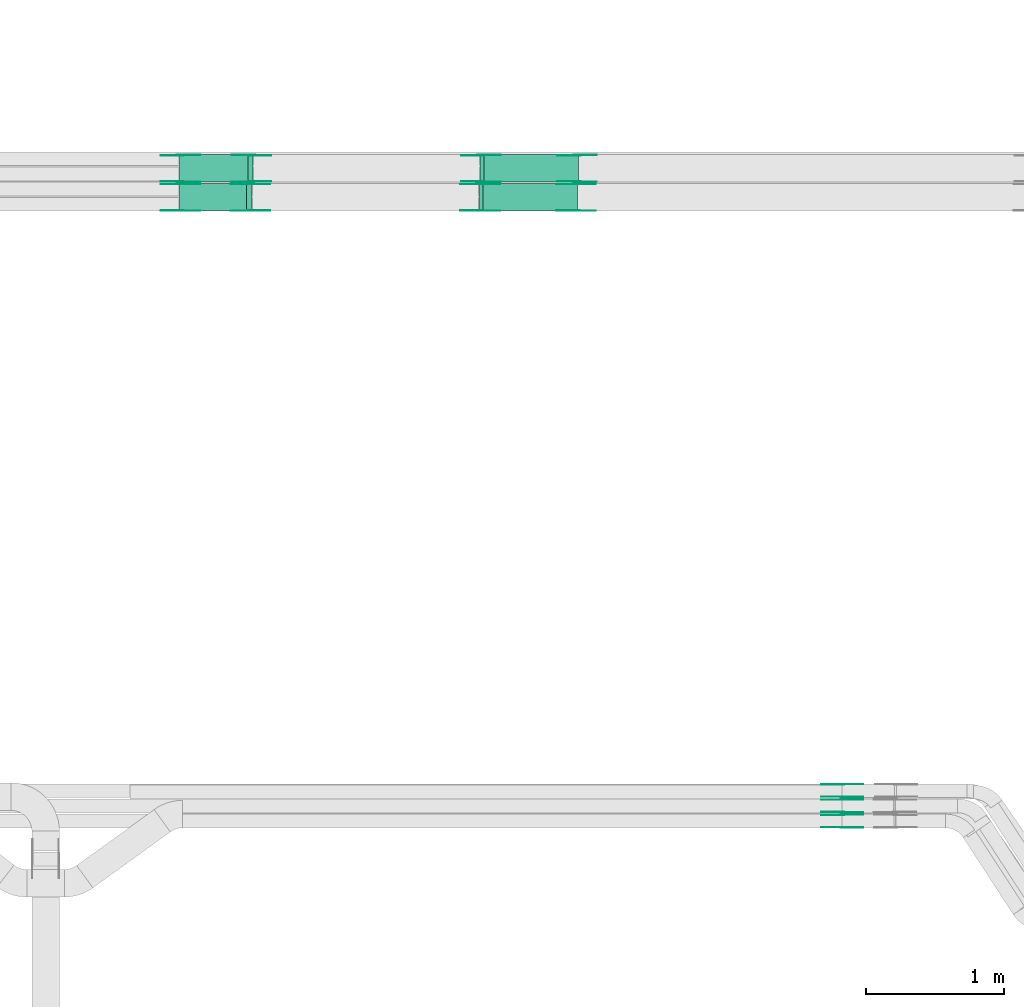
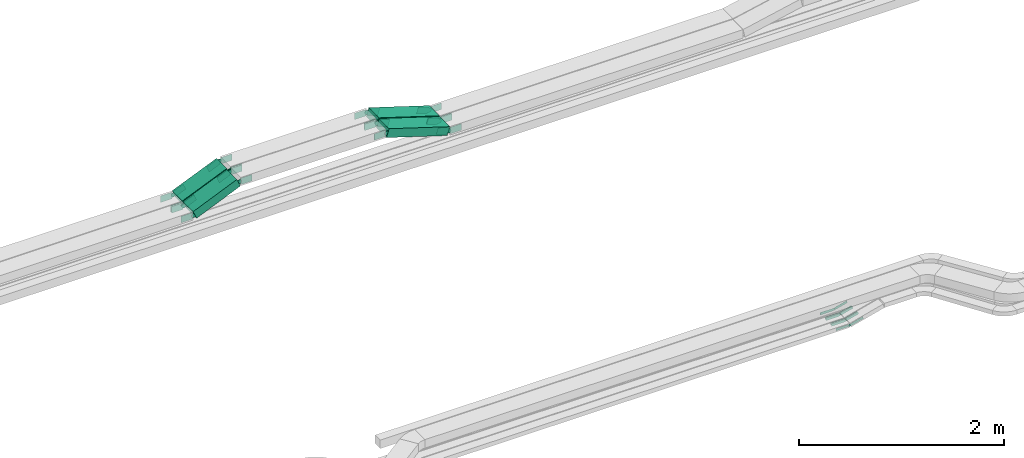
# One storey, part 6 of 23: 44 flow fittings, 4 flow segments.
"""IFC2X3 building model written with IfcOpenShell, lengths in millimetres."""

from ifc_helpers import new_model, entity, si_unit, converted_unit, derived_unit, direction, frame, frame_2d, origin, origin_2d_with_axis, place, context, subcontext, project, spatial, polyline, circle_curve, parameter, trimmed, segment, composite_curve, rectangle, outline, extrude, source, transform, mapped, material, type_object, type_shapes, element, save


model = new_model("IFC2X3")

# Units and contexts
model_context = context("Model", 3, precision=0.01, world=origin(), true_north=direction((6.12303176911189e-17, 1.0)))
body_context = subcontext(model_context, "Body", "Model", "MODEL_VIEW")
ifc_project = project(units=[si_unit("LENGTHUNIT", "METRE", prefix="MILLI"), si_unit("AREAUNIT", "SQUARE_METRE"), si_unit("VOLUMEUNIT", "CUBIC_METRE"), converted_unit("PLANEANGLEUNIT", "DEGREE", entity("IfcRatioMeasure", 0.0174532925199433), si_unit("PLANEANGLEUNIT", "RADIAN"), dimensions=[0, 0, 0, 0, 0, 0, 0]), si_unit("MASSUNIT", "GRAM", prefix="KILO"), derived_unit("MASSDENSITYUNIT", [(si_unit("MASSUNIT", "GRAM", prefix="KILO"), 1), (si_unit("LENGTHUNIT", "METRE"), -3)]), derived_unit("MOMENTOFINERTIAUNIT", [(si_unit("LENGTHUNIT", "METRE"), 4)]), si_unit("TIMEUNIT", "SECOND"), si_unit("FREQUENCYUNIT", "HERTZ"), si_unit("THERMODYNAMICTEMPERATUREUNIT", "DEGREE_CELSIUS"), derived_unit("THERMALTRANSMITTANCEUNIT", [(si_unit("MASSUNIT", "GRAM", prefix="KILO"), 1), (si_unit("THERMODYNAMICTEMPERATUREUNIT", "KELVIN"), -1), (si_unit("TIMEUNIT", "SECOND"), -3)]), derived_unit("VOLUMETRICFLOWRATEUNIT", [(si_unit("LENGTHUNIT", "METRE"), 3), (si_unit("TIMEUNIT", "SECOND"), -1)]), derived_unit("MASSFLOWRATEUNIT", [(si_unit("MASSUNIT", "GRAM", prefix="KILO"), 1), (si_unit("TIMEUNIT", "SECOND"), -1)]), derived_unit("ROTATIONALFREQUENCYUNIT", [(si_unit("TIMEUNIT", "SECOND"), -1)]), si_unit("ELECTRICCURRENTUNIT", "AMPERE"), si_unit("ELECTRICVOLTAGEUNIT", "VOLT"), si_unit("POWERUNIT", "WATT"), si_unit("FORCEUNIT", "NEWTON", prefix="KILO"), si_unit("ILLUMINANCEUNIT", "LUX"), si_unit("LUMINOUSFLUXUNIT", "LUMEN"), si_unit("LUMINOUSINTENSITYUNIT", "CANDELA"), derived_unit("USERDEFINED", [(si_unit("MASSUNIT", "GRAM", prefix="KILO"), -1), (si_unit("LENGTHUNIT", "METRE"), -2), (si_unit("TIMEUNIT", "SECOND"), 3), (si_unit("LUMINOUSFLUXUNIT", "LUMEN"), 1)]), derived_unit("LINEARVELOCITYUNIT", [(si_unit("LENGTHUNIT", "METRE"), 1), (si_unit("TIMEUNIT", "SECOND"), -1)]), si_unit("PRESSUREUNIT", "PASCAL"), derived_unit("USERDEFINED", [(si_unit("LENGTHUNIT", "METRE"), -2), (si_unit("MASSUNIT", "GRAM", prefix="KILO"), 1), (si_unit("TIMEUNIT", "SECOND"), -2)]), derived_unit("LINEARFORCEUNIT", [(si_unit("MASSUNIT", "GRAM", prefix="KILO"), 1), (si_unit("LENGTHUNIT", "METRE"), 1), (si_unit("TIMEUNIT", "SECOND"), -2), (si_unit("LENGTHUNIT", "METRE"), -1)]), derived_unit("PLANARFORCEUNIT", [(si_unit("MASSUNIT", "GRAM", prefix="KILO"), 1), (si_unit("LENGTHUNIT", "METRE"), 1), (si_unit("TIMEUNIT", "SECOND"), -2), (si_unit("LENGTHUNIT", "METRE"), -2)])], contexts=[model_context])

# Site, building, storey
site_placement = place(None, origin())
site = spatial("IfcSite", under=ifc_project, at=site_placement, CompositionType="ELEMENT")
building_placement = place(site_placement, origin())
building = spatial("IfcBuilding", under=site, at=building_placement, CompositionType="ELEMENT")
storey_placement = place(building_placement, frame((0.0, 0.0, 24000.0)))
storey = spatial("IfcBuildingStorey", under=building, at=storey_placement, CompositionType="ELEMENT", Elevation=24000.0)

# Flow segments
cable_carrier_segment_type = type_object("IfcCableCarrierSegmentType", PredefinedType="CABLETRAYSEGMENT")
flow_segment_1_placement = place(storey_placement, frame((23750.35, 14577.82, 2908.57)))
element("IfcFlowSegment", 1, at=flow_segment_1_placement, inside=storey, type_object=cable_carrier_segment_type, context=body_context, shape_type="SweptSolid", body=[
    extrude(rectangle(XDim=99.9999999999979, YDim=200.000000000002, at=origin_2d_with_axis()), frame((19.44, 100.0, 46.07), z_axis=(0.921307677757376, 0.0, 0.388834364357512), x_axis=(-0.388834364357512, 0.0, 0.921307677757376)), (0.0, 0.0, 1.0), 541.93656678797),
])
flow_segment_2_placement = place(storey_placement, frame((25932.66, 14577.82, 2905.08)))
element("IfcFlowSegment", 2, at=flow_segment_2_placement, inside=storey, type_object=cable_carrier_segment_type, context=body_context, shape_type="SweptSolid", body=[
    extrude(rectangle(XDim=99.9999999999984, YDim=200.000000000002, at=origin_2d_with_axis()), frame((14.99, 100.0, 262.13), z_axis=(0.953993716901251, 0.0, -0.299826596740408), x_axis=(0.299826596740408, 0.0, 0.953993716901251)), (0.0, 0.0, 1.0), 715.185612494235),
])
flow_segment_3_placement = place(storey_placement, frame((23750.22, 14367.82, 2908.78)))
element("IfcFlowSegment", 3, at=flow_segment_3_placement, inside=storey, type_object=cable_carrier_segment_type, context=body_context, shape_type="SweptSolid", body=[
    extrude(rectangle(XDim=99.9999999999976, YDim=200.000000000002, at=origin_2d_with_axis()), frame((19.67, 100.0, 45.97), z_axis=(0.919387135984397, 0.0, 0.393353904501287), x_axis=(-0.393353904501287, 0.0, 0.919387135984397)), (0.0, 0.0, 1.0), 535.159561068118),
])
flow_segment_4_placement = place(storey_placement, frame((25925.6, 14367.82, 2905.08)))
element("IfcFlowSegment", 4, at=flow_segment_4_placement, inside=storey, type_object=cable_carrier_segment_type, context=body_context, shape_type="SweptSolid", body=[
    extrude(rectangle(XDim=99.9999999999984, YDim=200.000000000002, at=origin_2d_with_axis()), frame((14.99, 100.0, 262.13), z_axis=(0.953993716901251, 0.0, -0.299826596740408), x_axis=(0.299826596740408, 0.0, 0.953993716901251)), (0.0, 0.0, 1.0), 715.185612494268),
])

# Flow fittings
ifc_material = material(Name="G")
cable_carrier_fitting_type_1 = type_object("IfcCableCarrierFittingType", PredefinedType="NOTDEFINED", material=ifc_material)
shared_shape_1 = source(origin(), body_context, "Body", "SweptSolid", [
    extrude(outline(composite_curve([segment(trimmed(circle_curve(frame_2d((-44.59, 0.0), x_axis=(1.0, 0.0)), 12.5), [parameter(90.0000000000007)], [parameter(270.0)], True, "PARAMETER"), True, "CONTINUOUS"), segment(polyline([(-44.59, -12.5), (-33.09, -12.5)]), True, "CONTINUOUS"), segment(polyline([(-33.09, -12.5), (-31.23, -14.5)]), True, "CONTINUOUS"), segment(polyline([(-31.23, -14.5), (108.91, -14.5)]), True, "CONTINUOUS"), segment(polyline([(108.91, -14.5), (108.91, 14.5)]), True, "CONTINUOUS"), segment(polyline([(108.91, 14.5), (-31.23, 14.5)]), True, "CONTINUOUS"), segment(polyline([(-31.23, 14.5), (-33.09, 12.5)]), True, "CONTINUOUS"), segment(polyline([(-33.09, 12.5), (-44.59, 12.5)]), True, "CONTINUOUS")], self_intersect=False)), frame((44.59, 0.0, 0.0), z_axis=(0.0, 0.0, -1.0), x_axis=(1.0, 0.0, 0.0)), (0.0, 0.0, -1.0), 2.0),
])
type_shapes(cable_carrier_fitting_type_1, [shared_shape_1])
flow_fitting_1_placement = place(storey_placement, frame((28559.4, 9902.36, 2675.0), z_axis=(0.0, -1.0, 0.0), x_axis=(0.967755764973795, 0.0, 0.251890411409375)))
element("IfcFlowFitting", 5, at=flow_fitting_1_placement, inside=storey, type_object=cable_carrier_fitting_type_1, material=ifc_material, context=body_context, shape_type="MappedRepresentation", body=[
    mapped(shared_shape_1, transform((0.0, 0.0, 0.0), scale=1.0)),
])
cable_carrier_fitting_type_2 = type_object("IfcCableCarrierFittingType", PredefinedType="NOTDEFINED", material=ifc_material)
type_shapes(cable_carrier_fitting_type_2, [shared_shape_1])
flow_fitting_2_placement = place(storey_placement, frame((28559.4, 9991.28, 2675.0), z_axis=(0.0, 1.0, 0.0), x_axis=(-1.0, 0.0, 0.0)))
element("IfcFlowFitting", 6, at=flow_fitting_2_placement, inside=storey, type_object=cable_carrier_fitting_type_2, material=ifc_material, context=body_context, shape_type="MappedRepresentation", body=[
    mapped(shared_shape_1, transform((0.0, 0.0, 0.0), scale=1.0)),
])
flow_fitting_3_placement = place(storey_placement, frame((28559.4, 10012.36, 2675.0), z_axis=(0.0, -1.0, 0.0), x_axis=(0.96722840614087, 0.0, 0.253907877692269)))
element("IfcFlowFitting", 7, at=flow_fitting_3_placement, inside=storey, type_object=cable_carrier_fitting_type_1, material=ifc_material, context=body_context, shape_type="MappedRepresentation", body=[
    mapped(shared_shape_1, transform((0.0, 0.0, 0.0), scale=1.0)),
])
flow_fitting_4_placement = place(storey_placement, frame((28559.4, 10101.28, 2675.0), z_axis=(0.0, 1.0, 0.0), x_axis=(-1.0, 0.0, -5.74450066331542e-08)))
element("IfcFlowFitting", 8, at=flow_fitting_4_placement, inside=storey, type_object=cable_carrier_fitting_type_2, material=ifc_material, context=body_context, shape_type="MappedRepresentation", body=[
    mapped(shared_shape_1, transform((0.0, 0.0, 0.0), scale=1.0)),
])
flow_fitting_5_placement = place(storey_placement, frame((28559.4, 10122.36, 2675.0), z_axis=(0.0, -1.0, 0.0), x_axis=(0.968482292862195, 0.0, 0.249082412892571)))
element("IfcFlowFitting", 9, at=flow_fitting_5_placement, inside=storey, type_object=cable_carrier_fitting_type_1, material=ifc_material, context=body_context, shape_type="MappedRepresentation", body=[
    mapped(shared_shape_1, transform((0.0, 0.0, 0.0), scale=1.0)),
])
flow_fitting_6_placement = place(storey_placement, frame((28559.4, 10211.28, 2675.0), z_axis=(0.0, 1.0, 0.0), x_axis=(-1.0, 0.0, -5.70149502338435e-08)))
element("IfcFlowFitting", 10, at=flow_fitting_6_placement, inside=storey, type_object=cable_carrier_fitting_type_2, material=ifc_material, context=body_context, shape_type="MappedRepresentation", body=[
    mapped(shared_shape_1, transform((0.0, 0.0, 0.0), scale=1.0)),
])
cable_carrier_fitting_type_3 = type_object("IfcCableCarrierFittingType", PredefinedType="NOTDEFINED", material=ifc_material)
shared_shape_2 = source(origin(), body_context, "Body", "SweptSolid", [
    extrude(outline(composite_curve([segment(trimmed(circle_curve(frame_2d((-44.59, 0.0), x_axis=(1.0, 0.0)), 12.5), [parameter(90.0000000000007)], [parameter(270.0)], True, "PARAMETER"), True, "CONTINUOUS"), segment(polyline([(-44.59, -12.5), (-33.09, -12.5)]), True, "CONTINUOUS"), segment(polyline([(-33.09, -12.5), (-31.23, -14.5)]), True, "CONTINUOUS"), segment(polyline([(-31.23, -14.5), (108.91, -14.5)]), True, "CONTINUOUS"), segment(polyline([(108.91, -14.5), (108.91, 14.5)]), True, "CONTINUOUS"), segment(polyline([(108.91, 14.5), (-31.23, 14.5)]), True, "CONTINUOUS"), segment(polyline([(-31.23, 14.5), (-33.09, 12.5)]), True, "CONTINUOUS"), segment(polyline([(-33.09, 12.5), (-44.59, 12.5)]), True, "CONTINUOUS")], self_intersect=False)), frame((44.59, 0.0, 0.0)), (0.0, 0.0, 1.0), 2.0),
])
type_shapes(cable_carrier_fitting_type_3, [shared_shape_2])
flow_fitting_7_placement = place(storey_placement, frame((28559.4, 9993.28, 2675.0), z_axis=(0.0, 1.0, 0.0), x_axis=(0.967755764973795, 0.0, 0.251890411409375)))
element("IfcFlowFitting", 11, at=flow_fitting_7_placement, inside=storey, type_object=cable_carrier_fitting_type_3, material=ifc_material, context=body_context, shape_type="MappedRepresentation", body=[
    mapped(shared_shape_2, transform((0.0, 0.0, 0.0), scale=1.0)),
])
cable_carrier_fitting_type_4 = type_object("IfcCableCarrierFittingType", PredefinedType="NOTDEFINED", material=ifc_material)
type_shapes(cable_carrier_fitting_type_4, [shared_shape_2])
flow_fitting_8_placement = place(storey_placement, frame((28559.4, 9904.36, 2675.0), z_axis=(0.0, -1.0, 0.0), x_axis=(-1.0, 0.0, 0.0)))
element("IfcFlowFitting", 12, at=flow_fitting_8_placement, inside=storey, type_object=cable_carrier_fitting_type_4, material=ifc_material, context=body_context, shape_type="MappedRepresentation", body=[
    mapped(shared_shape_2, transform((0.0, 0.0, 0.0), scale=1.0)),
])
flow_fitting_9_placement = place(storey_placement, frame((28559.4, 10103.28, 2675.0), z_axis=(0.0, 1.0, 0.0), x_axis=(0.96722840614087, 0.0, 0.253907877692269)))
element("IfcFlowFitting", 13, at=flow_fitting_9_placement, inside=storey, type_object=cable_carrier_fitting_type_3, material=ifc_material, context=body_context, shape_type="MappedRepresentation", body=[
    mapped(shared_shape_2, transform((0.0, 0.0, 0.0), scale=1.0)),
])
flow_fitting_10_placement = place(storey_placement, frame((28559.4, 10014.36, 2675.0), z_axis=(0.0, -1.0, 0.0), x_axis=(-1.0, 0.0, -5.74450066331542e-08)))
element("IfcFlowFitting", 14, at=flow_fitting_10_placement, inside=storey, type_object=cable_carrier_fitting_type_4, material=ifc_material, context=body_context, shape_type="MappedRepresentation", body=[
    mapped(shared_shape_2, transform((0.0, 0.0, 0.0), scale=1.0)),
])
flow_fitting_11_placement = place(storey_placement, frame((28559.4, 10213.28, 2675.0), z_axis=(0.0, 1.0, 0.0), x_axis=(0.968482292862195, 0.0, 0.249082412892571)))
element("IfcFlowFitting", 15, at=flow_fitting_11_placement, inside=storey, type_object=cable_carrier_fitting_type_3, material=ifc_material, context=body_context, shape_type="MappedRepresentation", body=[
    mapped(shared_shape_2, transform((0.0, 0.0, 0.0), scale=1.0)),
])
flow_fitting_12_placement = place(storey_placement, frame((28559.4, 10124.36, 2675.0), z_axis=(0.0, -1.0, 0.0), x_axis=(-1.0, 0.0, -5.70149502338435e-08)))
element("IfcFlowFitting", 16, at=flow_fitting_12_placement, inside=storey, type_object=cable_carrier_fitting_type_4, material=ifc_material, context=body_context, shape_type="MappedRepresentation", body=[
    mapped(shared_shape_2, transform((0.0, 0.0, 0.0), scale=1.0)),
])
cable_carrier_fitting_type_5 = type_object("IfcCableCarrierFittingType", PredefinedType="NOTDEFINED", material=ifc_material)
shared_shape_3 = source(origin(), body_context, "Body", "SweptSolid", [
    extrude(outline(composite_curve([segment(trimmed(circle_curve(frame_2d((-41.47, 0.0), x_axis=(1.0, 0.0)), 25.0), [parameter(90.0000000000007)], [parameter(270.0)], True, "PARAMETER"), True, "CONTINUOUS"), segment(polyline([(-41.47, -25.0), (-29.97, -25.0)]), True, "CONTINUOUS"), segment(polyline([(-29.97, -25.0), (-28.1, -38.5)]), True, "CONTINUOUS"), segment(polyline([(-28.1, -38.5), (99.53, -38.5)]), True, "CONTINUOUS"), segment(polyline([(99.53, -38.5), (99.53, 38.5)]), True, "CONTINUOUS"), segment(polyline([(99.53, 38.5), (-28.1, 38.5)]), True, "CONTINUOUS"), segment(polyline([(-28.1, 38.5), (-29.97, 25.0)]), True, "CONTINUOUS"), segment(polyline([(-29.97, 25.0), (-41.47, 25.0)]), True, "CONTINUOUS")], self_intersect=False)), frame((41.47, 0.0, 0.0), z_axis=(0.0, 0.0, -1.0), x_axis=(1.0, 0.0, 0.0)), (0.0, 0.0, -1.0), 2.0),
])
type_shapes(cable_carrier_fitting_type_5, [shared_shape_3])
flow_fitting_13_placement = place(storey_placement, frame((24280.07, 14582.36, 3170.0), z_axis=(0.0, -1.0, 0.0), x_axis=(-0.921307677757369, 0.0, -0.388834364357531)))
element("IfcFlowFitting", 17, at=flow_fitting_13_placement, inside=storey, type_object=cable_carrier_fitting_type_5, material=ifc_material, context=body_context, shape_type="MappedRepresentation", body=[
    mapped(shared_shape_3, transform((0.0, 0.0, 0.0), scale=1.0)),
])
cable_carrier_fitting_type_6 = type_object("IfcCableCarrierFittingType", PredefinedType="NOTDEFINED", material=ifc_material)
type_shapes(cable_carrier_fitting_type_6, [shared_shape_3])
flow_fitting_14_placement = place(storey_placement, frame((24280.07, 14771.28, 3170.0), z_axis=(0.0, 1.0, 0.0), x_axis=(1.0, 0.0, 0.0)))
element("IfcFlowFitting", 18, at=flow_fitting_14_placement, inside=storey, type_object=cable_carrier_fitting_type_6, material=ifc_material, context=body_context, shape_type="MappedRepresentation", body=[
    mapped(shared_shape_3, transform((0.0, 0.0, 0.0), scale=1.0)),
])
flow_fitting_15_placement = place(storey_placement, frame((23758.8, 14582.36, 2950.0), z_axis=(0.0, -1.0, 0.0), x_axis=(0.921307677757369, 0.0, 0.388834364357531)))
element("IfcFlowFitting", 19, at=flow_fitting_15_placement, inside=storey, type_object=cable_carrier_fitting_type_5, material=ifc_material, context=body_context, shape_type="MappedRepresentation", body=[
    mapped(shared_shape_3, transform((0.0, 0.0, 0.0), scale=1.0)),
])
flow_fitting_16_placement = place(storey_placement, frame((23758.8, 14771.28, 2950.0), z_axis=(0.0, 1.0, 0.0), x_axis=(-1.0, 0.0, 0.0)))
element("IfcFlowFitting", 20, at=flow_fitting_16_placement, inside=storey, type_object=cable_carrier_fitting_type_6, material=ifc_material, context=body_context, shape_type="MappedRepresentation", body=[
    mapped(shared_shape_3, transform((0.0, 0.0, 0.0), scale=1.0)),
])
flow_fitting_17_placement = place(storey_placement, frame((25938.8, 14773.28, 3170.0), z_axis=(0.0, 1.0, 0.0), x_axis=(0.953993716901241, 0.0, -0.299826596740441)))
element("IfcFlowFitting", 21, at=flow_fitting_17_placement, inside=storey, type_object=cable_carrier_fitting_type_5, material=ifc_material, context=body_context, shape_type="MappedRepresentation", body=[
    mapped(shared_shape_3, transform((0.0, 0.0, 0.0), scale=1.0)),
])
flow_fitting_18_placement = place(storey_placement, frame((25938.8, 14584.36, 3170.0), z_axis=(0.0, -1.0, 0.0), x_axis=(-1.0, 0.0, 0.0)))
element("IfcFlowFitting", 22, at=flow_fitting_18_placement, inside=storey, type_object=cable_carrier_fitting_type_6, material=ifc_material, context=body_context, shape_type="MappedRepresentation", body=[
    mapped(shared_shape_3, transform((0.0, 0.0, 0.0), scale=1.0)),
])
flow_fitting_19_placement = place(storey_placement, frame((24273.0, 14372.36, 3170.0), z_axis=(0.0, -1.0, 0.0), x_axis=(-0.919387135984396, 0.0, -0.39335390450129)))
element("IfcFlowFitting", 23, at=flow_fitting_19_placement, inside=storey, type_object=cable_carrier_fitting_type_5, material=ifc_material, context=body_context, shape_type="MappedRepresentation", body=[
    mapped(shared_shape_3, transform((0.0, 0.0, 0.0), scale=1.0)),
])
flow_fitting_20_placement = place(storey_placement, frame((24273.0, 14561.28, 3170.0), z_axis=(0.0, 1.0, 0.0), x_axis=(1.0, 0.0, 0.0)))
element("IfcFlowFitting", 24, at=flow_fitting_20_placement, inside=storey, type_object=cable_carrier_fitting_type_6, material=ifc_material, context=body_context, shape_type="MappedRepresentation", body=[
    mapped(shared_shape_3, transform((0.0, 0.0, 0.0), scale=1.0)),
])
flow_fitting_21_placement = place(storey_placement, frame((23758.8, 14372.36, 2950.0), z_axis=(0.0, -1.0, 0.0), x_axis=(0.919387135984396, 0.0, 0.39335390450129)))
element("IfcFlowFitting", 25, at=flow_fitting_21_placement, inside=storey, type_object=cable_carrier_fitting_type_5, material=ifc_material, context=body_context, shape_type="MappedRepresentation", body=[
    mapped(shared_shape_3, transform((0.0, 0.0, 0.0), scale=1.0)),
])
flow_fitting_22_placement = place(storey_placement, frame((23758.8, 14561.28, 2950.0), z_axis=(0.0, 1.0, 0.0), x_axis=(-1.0, 0.0, 0.0)))
element("IfcFlowFitting", 26, at=flow_fitting_22_placement, inside=storey, type_object=cable_carrier_fitting_type_6, material=ifc_material, context=body_context, shape_type="MappedRepresentation", body=[
    mapped(shared_shape_3, transform((0.0, 0.0, 0.0), scale=1.0)),
])
flow_fitting_23_placement = place(storey_placement, frame((25931.73, 14563.28, 3170.0), z_axis=(0.0, 1.0, 0.0), x_axis=(0.953993716901241, 0.0, -0.299826596740441)))
element("IfcFlowFitting", 27, at=flow_fitting_23_placement, inside=storey, type_object=cable_carrier_fitting_type_5, material=ifc_material, context=body_context, shape_type="MappedRepresentation", body=[
    mapped(shared_shape_3, transform((0.0, 0.0, 0.0), scale=1.0)),
])
flow_fitting_24_placement = place(storey_placement, frame((25931.73, 14374.36, 3170.0), z_axis=(0.0, -1.0, 0.0), x_axis=(-1.0, 0.0, 0.0)))
element("IfcFlowFitting", 28, at=flow_fitting_24_placement, inside=storey, type_object=cable_carrier_fitting_type_6, material=ifc_material, context=body_context, shape_type="MappedRepresentation", body=[
    mapped(shared_shape_3, transform((0.0, 0.0, 0.0), scale=1.0)),
])
flow_fitting_25_placement = place(storey_placement, frame((26638.8, 14582.36, 2950.0), z_axis=(0.0, -1.0, 0.0), x_axis=(1.0, 0.0, 0.0)))
element("IfcFlowFitting", 29, at=flow_fitting_25_placement, inside=storey, type_object=cable_carrier_fitting_type_5, material=ifc_material, context=body_context, shape_type="MappedRepresentation", body=[
    mapped(shared_shape_3, transform((0.0, 0.0, 0.0), scale=1.0)),
])
flow_fitting_26_placement = place(storey_placement, frame((26638.8, 14771.28, 2950.0), z_axis=(0.0, 1.0, 0.0), x_axis=(-0.953993716901243, 0.0, 0.299826596740433)))
element("IfcFlowFitting", 30, at=flow_fitting_26_placement, inside=storey, type_object=cable_carrier_fitting_type_6, material=ifc_material, context=body_context, shape_type="MappedRepresentation", body=[
    mapped(shared_shape_3, transform((0.0, 0.0, 0.0), scale=1.0)),
])
flow_fitting_27_placement = place(storey_placement, frame((26631.73, 14372.36, 2950.0), z_axis=(0.0, -1.0, 0.0), x_axis=(1.0, 0.0, 0.0)))
element("IfcFlowFitting", 31, at=flow_fitting_27_placement, inside=storey, type_object=cable_carrier_fitting_type_5, material=ifc_material, context=body_context, shape_type="MappedRepresentation", body=[
    mapped(shared_shape_3, transform((0.0, 0.0, 0.0), scale=1.0)),
])
flow_fitting_28_placement = place(storey_placement, frame((26631.73, 14561.28, 2950.0), z_axis=(0.0, 1.0, 0.0), x_axis=(-0.95399371690125, 0.0, 0.299826596740412)))
element("IfcFlowFitting", 32, at=flow_fitting_28_placement, inside=storey, type_object=cable_carrier_fitting_type_6, material=ifc_material, context=body_context, shape_type="MappedRepresentation", body=[
    mapped(shared_shape_3, transform((0.0, 0.0, 0.0), scale=1.0)),
])
cable_carrier_fitting_type_7 = type_object("IfcCableCarrierFittingType", PredefinedType="NOTDEFINED", material=ifc_material)
shared_shape_4 = source(origin(), body_context, "Body", "SweptSolid", [
    extrude(outline(composite_curve([segment(trimmed(circle_curve(frame_2d((-41.47, 0.0), x_axis=(1.0, 0.0)), 25.0), [parameter(90.0000000000007)], [parameter(270.0)], True, "PARAMETER"), True, "CONTINUOUS"), segment(polyline([(-41.47, -25.0), (-29.97, -25.0)]), True, "CONTINUOUS"), segment(polyline([(-29.97, -25.0), (-28.1, -38.5)]), True, "CONTINUOUS"), segment(polyline([(-28.1, -38.5), (99.53, -38.5)]), True, "CONTINUOUS"), segment(polyline([(99.53, -38.5), (99.53, 38.5)]), True, "CONTINUOUS"), segment(polyline([(99.53, 38.5), (-28.1, 38.5)]), True, "CONTINUOUS"), segment(polyline([(-28.1, 38.5), (-29.97, 25.0)]), True, "CONTINUOUS"), segment(polyline([(-29.97, 25.0), (-41.47, 25.0)]), True, "CONTINUOUS")], self_intersect=False)), frame((41.47, 0.0, 0.0)), (0.0, 0.0, 1.0), 2.0),
])
type_shapes(cable_carrier_fitting_type_7, [shared_shape_4])
flow_fitting_29_placement = place(storey_placement, frame((24280.07, 14773.28, 3170.0), z_axis=(0.0, 1.0, 0.0), x_axis=(-0.921307677757369, 0.0, -0.388834364357531)))
element("IfcFlowFitting", 33, at=flow_fitting_29_placement, inside=storey, type_object=cable_carrier_fitting_type_7, material=ifc_material, context=body_context, shape_type="MappedRepresentation", body=[
    mapped(shared_shape_4, transform((0.0, 0.0, 0.0), scale=1.0)),
])
cable_carrier_fitting_type_8 = type_object("IfcCableCarrierFittingType", PredefinedType="NOTDEFINED", material=ifc_material)
type_shapes(cable_carrier_fitting_type_8, [shared_shape_4])
flow_fitting_30_placement = place(storey_placement, frame((24280.07, 14584.36, 3170.0), z_axis=(0.0, -1.0, 0.0), x_axis=(1.0, 0.0, 0.0)))
element("IfcFlowFitting", 34, at=flow_fitting_30_placement, inside=storey, type_object=cable_carrier_fitting_type_8, material=ifc_material, context=body_context, shape_type="MappedRepresentation", body=[
    mapped(shared_shape_4, transform((0.0, 0.0, 0.0), scale=1.0)),
])
flow_fitting_31_placement = place(storey_placement, frame((23758.8, 14773.28, 2950.0), z_axis=(0.0, 1.0, 0.0), x_axis=(0.921307677757369, 0.0, 0.388834364357531)))
element("IfcFlowFitting", 35, at=flow_fitting_31_placement, inside=storey, type_object=cable_carrier_fitting_type_7, material=ifc_material, context=body_context, shape_type="MappedRepresentation", body=[
    mapped(shared_shape_4, transform((0.0, 0.0, 0.0), scale=1.0)),
])
flow_fitting_32_placement = place(storey_placement, frame((23758.8, 14584.36, 2950.0), z_axis=(0.0, -1.0, 0.0), x_axis=(-1.0, 0.0, 0.0)))
element("IfcFlowFitting", 36, at=flow_fitting_32_placement, inside=storey, type_object=cable_carrier_fitting_type_8, material=ifc_material, context=body_context, shape_type="MappedRepresentation", body=[
    mapped(shared_shape_4, transform((0.0, 0.0, 0.0), scale=1.0)),
])
flow_fitting_33_placement = place(storey_placement, frame((25938.8, 14582.36, 3170.0), z_axis=(0.0, -1.0, 0.0), x_axis=(0.953993716901241, 0.0, -0.299826596740441)))
element("IfcFlowFitting", 37, at=flow_fitting_33_placement, inside=storey, type_object=cable_carrier_fitting_type_7, material=ifc_material, context=body_context, shape_type="MappedRepresentation", body=[
    mapped(shared_shape_4, transform((0.0, 0.0, 0.0), scale=1.0)),
])
flow_fitting_34_placement = place(storey_placement, frame((25938.8, 14771.28, 3170.0), z_axis=(0.0, 1.0, 0.0), x_axis=(-1.0, 0.0, 0.0)))
element("IfcFlowFitting", 38, at=flow_fitting_34_placement, inside=storey, type_object=cable_carrier_fitting_type_8, material=ifc_material, context=body_context, shape_type="MappedRepresentation", body=[
    mapped(shared_shape_4, transform((0.0, 0.0, 0.0), scale=1.0)),
])
flow_fitting_35_placement = place(storey_placement, frame((24273.0, 14563.28, 3170.0), z_axis=(0.0, 1.0, 0.0), x_axis=(-0.919387135984396, 0.0, -0.39335390450129)))
element("IfcFlowFitting", 39, at=flow_fitting_35_placement, inside=storey, type_object=cable_carrier_fitting_type_7, material=ifc_material, context=body_context, shape_type="MappedRepresentation", body=[
    mapped(shared_shape_4, transform((0.0, 0.0, 0.0), scale=1.0)),
])
flow_fitting_36_placement = place(storey_placement, frame((24273.0, 14374.36, 3170.0), z_axis=(0.0, -1.0, 0.0), x_axis=(1.0, 0.0, 0.0)))
element("IfcFlowFitting", 40, at=flow_fitting_36_placement, inside=storey, type_object=cable_carrier_fitting_type_8, material=ifc_material, context=body_context, shape_type="MappedRepresentation", body=[
    mapped(shared_shape_4, transform((0.0, 0.0, 0.0), scale=1.0)),
])
flow_fitting_37_placement = place(storey_placement, frame((23758.8, 14563.28, 2950.0), z_axis=(0.0, 1.0, 0.0), x_axis=(0.919387135984396, 0.0, 0.39335390450129)))
element("IfcFlowFitting", 41, at=flow_fitting_37_placement, inside=storey, type_object=cable_carrier_fitting_type_7, material=ifc_material, context=body_context, shape_type="MappedRepresentation", body=[
    mapped(shared_shape_4, transform((0.0, 0.0, 0.0), scale=1.0)),
])
flow_fitting_38_placement = place(storey_placement, frame((23758.8, 14374.36, 2950.0), z_axis=(0.0, -1.0, 0.0), x_axis=(-1.0, 0.0, 0.0)))
element("IfcFlowFitting", 42, at=flow_fitting_38_placement, inside=storey, type_object=cable_carrier_fitting_type_8, material=ifc_material, context=body_context, shape_type="MappedRepresentation", body=[
    mapped(shared_shape_4, transform((0.0, 0.0, 0.0), scale=1.0)),
])
flow_fitting_39_placement = place(storey_placement, frame((25931.73, 14372.36, 3170.0), z_axis=(0.0, -1.0, 0.0), x_axis=(0.953993716901241, 0.0, -0.299826596740441)))
element("IfcFlowFitting", 43, at=flow_fitting_39_placement, inside=storey, type_object=cable_carrier_fitting_type_7, material=ifc_material, context=body_context, shape_type="MappedRepresentation", body=[
    mapped(shared_shape_4, transform((0.0, 0.0, 0.0), scale=1.0)),
])
flow_fitting_40_placement = place(storey_placement, frame((25931.73, 14561.28, 3170.0), z_axis=(0.0, 1.0, 0.0), x_axis=(-1.0, 0.0, 0.0)))
element("IfcFlowFitting", 44, at=flow_fitting_40_placement, inside=storey, type_object=cable_carrier_fitting_type_8, material=ifc_material, context=body_context, shape_type="MappedRepresentation", body=[
    mapped(shared_shape_4, transform((0.0, 0.0, 0.0), scale=1.0)),
])
flow_fitting_41_placement = place(storey_placement, frame((26638.8, 14773.28, 2950.0), z_axis=(0.0, 1.0, 0.0), x_axis=(1.0, 0.0, 0.0)))
element("IfcFlowFitting", 45, at=flow_fitting_41_placement, inside=storey, type_object=cable_carrier_fitting_type_7, material=ifc_material, context=body_context, shape_type="MappedRepresentation", body=[
    mapped(shared_shape_4, transform((0.0, 0.0, 0.0), scale=1.0)),
])
flow_fitting_42_placement = place(storey_placement, frame((26638.8, 14584.36, 2950.0), z_axis=(0.0, -1.0, 0.0), x_axis=(-0.953993716901243, 0.0, 0.299826596740433)))
element("IfcFlowFitting", 46, at=flow_fitting_42_placement, inside=storey, type_object=cable_carrier_fitting_type_8, material=ifc_material, context=body_context, shape_type="MappedRepresentation", body=[
    mapped(shared_shape_4, transform((0.0, 0.0, 0.0), scale=1.0)),
])
flow_fitting_43_placement = place(storey_placement, frame((26631.73, 14563.28, 2950.0), z_axis=(0.0, 1.0, 0.0), x_axis=(1.0, 0.0, 0.0)))
element("IfcFlowFitting", 47, at=flow_fitting_43_placement, inside=storey, type_object=cable_carrier_fitting_type_7, material=ifc_material, context=body_context, shape_type="MappedRepresentation", body=[
    mapped(shared_shape_4, transform((0.0, 0.0, 0.0), scale=1.0)),
])
flow_fitting_44_placement = place(storey_placement, frame((26631.73, 14374.36, 2950.0), z_axis=(0.0, -1.0, 0.0), x_axis=(-0.95399371690125, 0.0, 0.299826596740412)))
element("IfcFlowFitting", 48, at=flow_fitting_44_placement, inside=storey, type_object=cable_carrier_fitting_type_8, material=ifc_material, context=body_context, shape_type="MappedRepresentation", body=[
    mapped(shared_shape_4, transform((0.0, 0.0, 0.0), scale=1.0)),
])

save(model, "model.ifc")
